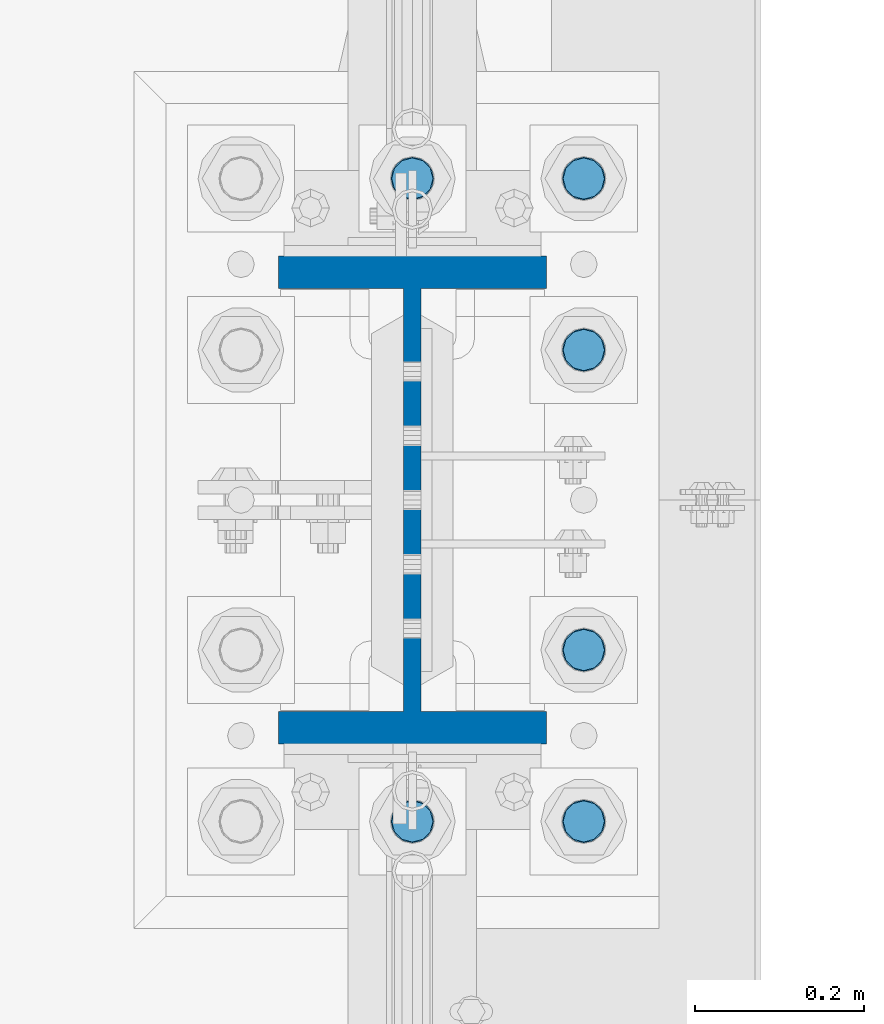
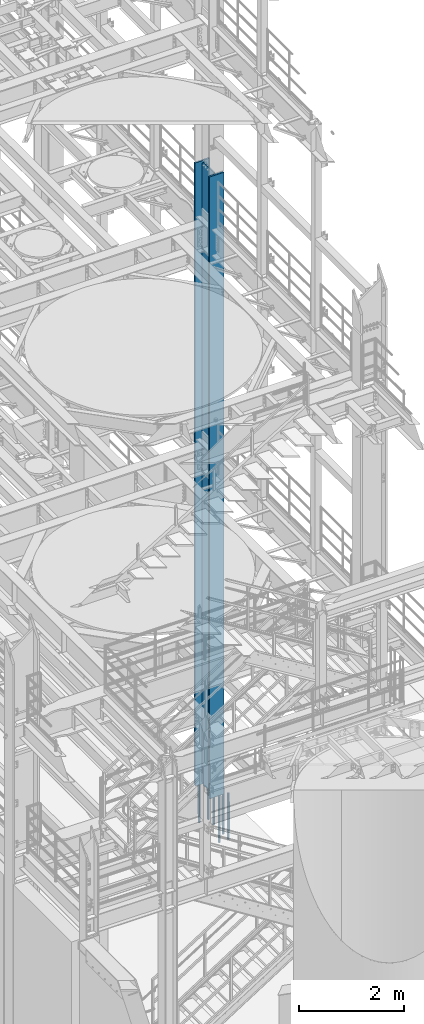
# One storey, part 715 of 1876: 7 columns, 2 elements without a shape of their own.
"""IFC2X3 building model written with IfcOpenShell, lengths in millimetres."""

from ifc_helpers import new_model, si_unit, frame, origin_with_axes, place, context, subcontext, project, spatial, faceted_brep, material, type_object, element, aggregate, save


model = new_model("IFC2X3")

# Units and contexts
model_context = context("Model", 3, precision=1e-05, world=origin_with_axes())
body_context = subcontext(model_context, "Body", "Model", "MODEL_VIEW")
ifc_project = project(units=[si_unit("LENGTHUNIT", "METRE", prefix="MILLI"), si_unit("AREAUNIT", "SQUARE_METRE"), si_unit("VOLUMEUNIT", "CUBIC_METRE"), si_unit("MASSUNIT", "GRAM", prefix="KILO"), si_unit("TIMEUNIT", "SECOND"), si_unit("PLANEANGLEUNIT", "RADIAN"), si_unit("SOLIDANGLEUNIT", "STERADIAN"), si_unit("THERMODYNAMICTEMPERATUREUNIT", "DEGREE_CELSIUS"), si_unit("LUMINOUSINTENSITYUNIT", "LUMEN")], contexts=[model_context])

# Site, building, storey
site_placement = place(None, origin_with_axes())
site = spatial("IfcSite", under=ifc_project, at=site_placement, CompositionType="ELEMENT")
building_placement = place(site_placement, origin_with_axes())
building = spatial("IfcBuilding", under=site, at=building_placement, Name="Undefined", CompositionType="ELEMENT")
storey_placement = place(building_placement, origin_with_axes())
storey = spatial("IfcBuildingStorey", under=building, at=storey_placement, Name="Undefined", CompositionType="ELEMENT", Elevation=0.0)

# Assembly, column
assembly_1_placement = place(storey_placement, origin_with_axes())
assembly_1 = element("IfcElementAssembly", 1, at=assembly_1_placement, inside=storey, Name="COLUMN", AssemblyPlace="NOTDEFINED", PredefinedType="RIGID_FRAME")
ifc_material_1 = material(Name="STEEL/A992")
column_type_1 = type_object("IfcColumnType", Name="W21X182", PredefinedType="NOTDEFINED")
column_1_placement = place(assembly_1_placement, frame((7620.0, 1524.0, 0.0), z_axis=(0.0, 1.0, 0.0), x_axis=(0.0, 0.0, 1.0)))
column_1 = element("IfcColumn", 2, at=column_1_placement, type_object=column_type_1, material=ifc_material_1, Name="COLUMN", ObjectType="W21X182", context=body_context, shape_type="Brep", body=[
    faceted_brep([(115.887500412823, 10.3187499999967, 200.025000762939), (115.887500412823, 10.3187500000004, -200.025000762939), (95.25, -10.3187500000004, -200.025000762939), (95.25, -10.3187500000004, 200.025000762939), (14528.8, -158.75, 288.925), (14528.8, 158.75, 288.925), (133.350000412822, 158.75, 288.925), (133.350000412824, -158.75, 288.925), (146.050000412824, -158.75, 250.825), (14478.0, -158.75, 250.825), (14528.8, -158.75, 250.825), (95.25, -158.75, 250.825), (146.050000412823, -10.3187500000004, 250.825), (14478.0, -10.3187500000004, 250.825), (14528.8, -10.3187500000004, 250.825), (95.25, -10.3187500000004, 250.825), (14528.8, -158.75, -288.925), (14528.8, -158.75, -250.825), (14478.0000007629, -158.75, -250.825), (146.050000412824, -158.75, -250.825), (95.25, -158.75, -250.825), (133.350000412824, -158.75, -288.925), (14528.8, 158.75, -288.925), (133.350000412822, 158.75, -288.925), (146.050000412824, 158.75, -250.825), (14478.0000007629, 158.75, -250.825), (14528.8, 158.75, -250.825), (95.25, 158.75, -250.825), (14528.8, 10.3187500000004, -250.825), (14528.8, -10.3187500000004, -250.825), (14478.0000007629, -10.3187500000004, -250.825), (146.050000412824, -10.3187500000004, -250.825), (95.25, -10.3187500000004, -250.825), (120.650000794293, -10.3187500000004, -200.025000762939), (120.650000794293, 10.3187500000004, -200.025000762939), (130.370159830384, 10.3187500000004, -201.958460608115), (130.370159830384, -10.3187500000004, -201.958460608115), (138.610512766692, 10.3187500000004, -207.464488409071), (138.610512766692, -10.3187500000004, -207.464488409071), (144.116540567648, 10.3187500000004, -215.704841345378), (144.116540567648, -10.3187500000004, -215.704841345378), (146.050000412823, 10.3187500000004, -225.42500038147), (146.050000412823, -10.3187500000004, -225.42500038147), (146.050000412824, 10.3187500000004, -250.825), (95.25, 10.3187500000004, -250.825), (14478.0000007629, 10.3187500000004, -250.825), (14481.8669204533, 10.3187500000004, -231.384681927818), (14481.8669204533, -10.3187500000004, -231.384681927818), (14492.8789760552, 10.3187500000004, -214.903976055203), (14492.8789760552, -10.3187500000004, -214.903976055203), (14509.3596819278, 10.3187500000004, -203.891920453291), (14509.3596819278, -10.3187500000004, -203.891920453291), (14528.8, -10.3187500000004, -200.025000762939), (14528.8, 10.3187500000004, -200.025000762939), (14528.8, 10.3187500000004, 200.025000762939), (14528.8, -10.3187500000004, 200.025000762939), (14509.3596811649, 10.3187500000004, 203.891920453291), (14509.3596811649, -10.3187500000004, 203.891920453291), (14492.8789752923, 10.3187500000004, 214.903976055203), (14492.8789752923, -10.3187500000004, 214.903976055203), (14481.8669196904, 10.3187500000004, 231.384681927818), (14481.8669196904, -10.3187500000004, 231.384681927818), (14478.0, 10.3187500000004, 250.825), (14528.8, 10.3187500000004, 250.825), (14528.8, 158.75, 250.825), (14478.0, 158.75, 250.825), (146.050000412824, 158.75, 250.825), (95.25, 158.75, 250.825), (95.25, 10.3187500000004, 250.825), (146.050000412824, 10.3187500000004, 250.825), (146.050000412823, 10.3187500000004, 225.42500038147), (146.050000412823, -10.3187500000004, 225.42500038147), (144.116540567648, 10.3187500000004, 215.704841345378), (144.116540567648, -10.3187500000004, 215.704841345378), (138.610512766692, 10.3187500000004, 207.464488409071), (138.610512766692, -10.3187500000004, 207.464488409071), (130.370159830384, 10.3187500000004, 201.958460608115), (130.370159830384, -10.3187500000004, 201.958460608115), (120.650000794293, 10.3187500000004, 200.025000762939), (120.650000794293, -10.3187500000004, 200.025000762939)], [[[0, 1, 2, 3]], [[4, 5, 6, 7]], [[8, 9, 10, 4, 7, 11]], [[12, 13, 14, 10, 9, 8, 11, 15]], [[16, 17, 18, 19, 20, 21]], [[22, 16, 21, 23]], [[24, 25, 26, 22, 23, 27]], [[17, 16, 22, 26, 28, 29]], [[19, 18, 17, 29, 30, 31, 32, 20]], [[33, 34, 35, 36]], [[36, 35, 37, 38]], [[38, 37, 39, 40]], [[40, 39, 41, 42]], [[42, 41, 43, 31]], [[31, 43, 44, 32]], [[27, 23, 21, 20, 32, 44]], [[43, 45, 28, 26, 25, 24, 27, 44]], [[29, 28, 45, 30]], [[30, 45, 46, 47]], [[47, 46, 48, 49]], [[49, 48, 50, 51]], [[52, 51, 50, 53]], [[54, 55, 52, 53]], [[55, 54, 56, 57]], [[57, 56, 58, 59]], [[59, 58, 60, 61]], [[61, 60, 62, 13]], [[14, 13, 62, 63]], [[64, 5, 4, 10, 14, 63]], [[5, 64, 65, 66, 67, 6]], [[11, 7, 6, 67, 68, 15]], [[66, 65, 64, 63, 62, 69, 68, 67]], [[15, 68, 69, 12]], [[12, 69, 70, 71]], [[71, 70, 72, 73]], [[73, 72, 74, 75]], [[75, 74, 76, 77]], [[77, 76, 78, 79]], [[79, 78, 0, 3]], [[33, 36, 38, 40, 42, 31, 30, 47, 49, 51, 52, 55, 57, 59, 61, 13, 12, 71, 73, 75, 77, 79, 3, 2]], [[34, 33, 2, 1]], [[78, 76, 74, 72, 70, 69, 62, 60, 58, 56, 54, 53, 50, 48, 46, 45, 43, 41, 39, 37, 35, 34, 1, 0]]]),
])
aggregate(assembly_1, [column_1])

# Assembly, columns
assembly_2_placement = place(storey_placement, origin_with_axes())
assembly_2 = element("IfcElementAssembly", 3, at=assembly_2_placement, inside=storey, Name="TEMPLATE", AssemblyPlace="NOTDEFINED", PredefinedType="RIGID_FRAME")
ifc_material_2 = material(Name="STEEL/F1554-GR.105")
column_type_2 = type_object("IfcColumnType", PredefinedType="NOTDEFINED")
column_2_placement = place(assembly_2_placement, frame((7620.0, 1143.0, 0.0), z_axis=(0.0, -1.0, 0.0), x_axis=(0.0, 0.0, -1.0)))
column_2 = element("IfcColumn", 4, at=column_2_placement, type_object=column_type_2, material=ifc_material_2, Name="ANCHOR_BOLTS", context=body_context, shape_type="Brep", body=[
    faceted_brep([(-196.85, -21.217622392719, 12.25), (-196.85, -12.25, 21.2176223927188), (-196.85, 0.0, 24.5), (-196.85, 12.25, 21.2176223927188), (-196.85, 21.217622392719, 12.25), (-196.85, 24.5, 0.0), (-196.85, 21.217622392719, -12.25), (-196.85, 12.25, -21.2176223927188), (-196.85, 0.0, -24.5), (-196.85, -12.25, -21.2176223927188), (-196.85, -21.217622392719, -12.25), (-196.85, -24.5, 0.0), (0.0, 24.5, 0.0), (0.0, 21.217622392719, -12.25), (0.0, 12.25, -21.2176223927188), (0.0, 0.0, -24.5), (0.0, -12.25, -21.2176223927188), (0.0, -21.217622392719, -12.25), (0.0, -24.5, 0.0), (0.0, -21.217622392719, 12.25), (0.0, -12.25, 21.2176223927188), (0.0, 0.0, 24.5), (0.0, 12.25, 21.2176223927188), (0.0, 21.217622392719, 12.25), (0.0, -23.4665401257871, 9.7201591820733), (0.0, -17.9605122421381, 17.9605122421383), (0.0, -9.72015918207308, 23.4665401257867), (0.0, 0.0, 25.4000000000001), (0.0, 9.72015918207308, 23.4665401257867), (0.0, 17.9605122421381, 17.9605122421383), (0.0, 23.4665401257871, 9.7201591820733), (0.0, 25.3999996185339, 9.09494701772928e-13), (0.0, 23.4665401257871, -9.7201591820733), (0.0, 17.9605122421381, -17.9605122421383), (0.0, 9.72015918207308, -23.4665401257867), (0.0, 0.0, -25.4000000000001), (0.0, -9.72015918207308, -23.4665401257867), (0.0, -17.9605122421381, -17.9605122421383), (0.0, -23.4665401257871, -9.7201591820733), (0.0, -25.3999996185375, 0.0), (673.1, -25.3999999999996, 0.0), (673.1, -23.4665401257871, 9.7201591820733), (673.1, -17.9605122421381, 17.9605122421383), (673.1, -9.72015918207308, 23.4665401257867), (673.1, 0.0, 25.4000000000001), (673.1, 9.72015918207308, 23.4665401257867), (673.1, 17.9605122421381, 17.9605122421383), (673.1, 23.4665401257871, 9.7201591820733), (673.1, 25.3999999999996, 0.0), (673.1, 23.4665401257871, -9.7201591820733), (673.1, 17.9605122421381, -17.9605122421383), (673.1, 9.72015918207308, -23.4665401257867), (673.1, 0.0, -25.4000000000001), (673.1, -9.72015918207308, -23.4665401257867), (673.1, -17.9605122421381, -17.9605122421383), (673.1, -23.4665401257871, -9.7201591820733), (673.1, -12.25, 21.2176223927188), (673.1, 0.0, 24.5), (673.1, 12.25, 21.2176223927188), (673.1, 21.217622392719, 12.25), (673.1, 24.5, 0.0), (673.1, 21.217622392719, -12.25), (673.1, 12.25, -21.2176223927188), (673.1, 0.0, -24.5), (673.1, -12.25, -21.2176223927188), (673.1, -21.217622392719, -12.25), (673.1, -24.5, 0.0), (673.1, -21.217622392719, 12.25), (869.95, -12.25, -21.2176223927188), (869.95, 0.0, -24.5), (869.95, 12.25, -21.2176223927188), (869.95, 21.217622392719, -12.25), (869.95, 24.5, 0.0), (869.95, 21.217622392719, 12.25), (869.95, 12.25, 21.2176223927188), (869.95, 0.0, 24.5), (869.95, -12.25, 21.2176223927188), (869.95, -21.217622392719, 12.25), (869.95, -24.5, 0.0), (869.95, -21.217622392719, -12.25)], [[[0, 1, 2, 3, 4, 5, 6, 7, 8, 9, 10, 11]], [[6, 5, 12, 13]], [[7, 6, 13, 14]], [[8, 7, 14, 15]], [[9, 8, 15, 16]], [[10, 9, 16, 17]], [[11, 10, 17, 18]], [[0, 11, 18, 19]], [[1, 0, 19, 20]], [[2, 1, 20, 21]], [[3, 2, 21, 22]], [[4, 3, 22, 23]], [[5, 4, 23, 12]], [[24, 25, 26, 27, 28, 29, 30, 31, 32, 33, 34, 35, 36, 37, 38, 39], [22, 21, 20, 19, 18, 17, 16, 15, 14, 13, 12, 23]], [[24, 39, 40, 41]], [[25, 24, 41, 42]], [[26, 25, 42, 43]], [[27, 26, 43, 44]], [[28, 27, 44, 45]], [[29, 28, 45, 46]], [[30, 29, 46, 47]], [[31, 30, 47, 48]], [[32, 31, 48, 49]], [[33, 32, 49, 50]], [[34, 33, 50, 51]], [[35, 34, 51, 52]], [[36, 35, 52, 53]], [[37, 36, 53, 54]], [[38, 37, 54, 55]], [[39, 38, 55, 40]], [[54, 53, 52, 51, 50, 49, 48, 47, 46, 45, 44, 43, 42, 41, 40, 55], [56, 57, 58, 59, 60, 61, 62, 63, 64, 65, 66, 67]], [[68, 69, 70, 71, 72, 73, 74, 75, 76, 77, 78, 79]], [[76, 75, 57, 56]], [[77, 76, 56, 67]], [[78, 77, 67, 66]], [[79, 78, 66, 65]], [[68, 79, 65, 64]], [[69, 68, 64, 63]], [[70, 69, 63, 62]], [[71, 70, 62, 61]], [[72, 71, 61, 60]], [[73, 72, 60, 59]], [[74, 73, 59, 58]], [[75, 74, 58, 57]]]),
])
column_3_placement = place(assembly_2_placement, frame((7823.2, 1143.0, 0.0), z_axis=(0.0, 1.0, 0.0), x_axis=(0.0, 0.0, -1.0)))
column_3 = element("IfcColumn", 5, at=column_3_placement, type_object=column_type_2, material=ifc_material_2, Name="ANCHOR_BOLTS", context=body_context, shape_type="Brep", body=[
    faceted_brep([(-196.85, -21.217622392719, 12.25), (-196.85, -12.25, 21.2176223927188), (-196.85, 0.0, 24.5), (-196.85, 12.25, 21.2176223927188), (-196.85, 21.217622392719, 12.25), (-196.85, 24.5, 0.0), (-196.85, 21.217622392719, -12.25), (-196.85, 12.25, -21.2176223927188), (-196.85, 0.0, -24.5), (-196.85, -12.25, -21.2176223927188), (-196.85, -21.217622392719, -12.25), (-196.85, -24.5, 0.0), (0.0, 24.5, 0.0), (0.0, 21.217622392719, -12.25), (0.0, 12.25, -21.2176223927188), (0.0, 0.0, -24.5), (0.0, -12.25, -21.2176223927188), (0.0, -21.217622392719, -12.25), (0.0, -24.5, 0.0), (0.0, -21.217622392719, 12.25), (0.0, -12.25, 21.2176223927188), (0.0, 0.0, 24.5), (0.0, 12.25, 21.2176223927188), (0.0, 21.217622392719, 12.25), (0.0, -23.4665401257871, 9.7201591820733), (0.0, -17.9605122421381, 17.9605122421383), (0.0, -9.72015918207308, 23.4665401257867), (0.0, 0.0, 25.4000000000001), (0.0, 9.72015918207308, 23.4665401257867), (0.0, 17.9605122421381, 17.9605122421383), (0.0, 23.4665401257871, 9.7201591820733), (0.0, 25.3999996185339, 9.09494701772928e-13), (0.0, 23.4665401257871, -9.7201591820733), (0.0, 17.9605122421381, -17.9605122421383), (0.0, 9.72015918207308, -23.4665401257867), (0.0, 0.0, -25.4000000000001), (0.0, -9.72015918207308, -23.4665401257867), (0.0, -17.9605122421381, -17.9605122421383), (0.0, -23.4665401257871, -9.7201591820733), (0.0, -25.3999996185375, 0.0), (673.1, -25.3999999999996, 0.0), (673.1, -23.4665401257871, 9.7201591820733), (673.1, -17.9605122421381, 17.9605122421383), (673.1, -9.72015918207308, 23.4665401257867), (673.1, 0.0, 25.4000000000001), (673.1, 9.72015918207308, 23.4665401257867), (673.1, 17.9605122421381, 17.9605122421383), (673.1, 23.4665401257871, 9.7201591820733), (673.1, 25.3999999999996, 0.0), (673.1, 23.4665401257871, -9.7201591820733), (673.1, 17.9605122421381, -17.9605122421383), (673.1, 9.72015918207308, -23.4665401257867), (673.1, 0.0, -25.4000000000001), (673.1, -9.72015918207308, -23.4665401257867), (673.1, -17.9605122421381, -17.9605122421383), (673.1, -23.4665401257871, -9.7201591820733), (673.1, -12.25, 21.2176223927188), (673.1, 0.0, 24.5), (673.1, 12.25, 21.2176223927188), (673.1, 21.217622392719, 12.25), (673.1, 24.5, 0.0), (673.1, 21.217622392719, -12.25), (673.1, 12.25, -21.2176223927188), (673.1, 0.0, -24.5), (673.1, -12.25, -21.2176223927188), (673.1, -21.217622392719, -12.25), (673.1, -24.5, 0.0), (673.1, -21.217622392719, 12.25), (869.95, -12.25, -21.2176223927188), (869.95, 0.0, -24.5), (869.95, 12.25, -21.2176223927188), (869.95, 21.217622392719, -12.25), (869.95, 24.5, 0.0), (869.95, 21.217622392719, 12.25), (869.95, 12.25, 21.2176223927188), (869.95, 0.0, 24.5), (869.95, -12.25, 21.2176223927188), (869.95, -21.217622392719, 12.25), (869.95, -24.5, 0.0), (869.95, -21.217622392719, -12.25)], [[[0, 1, 2, 3, 4, 5, 6, 7, 8, 9, 10, 11]], [[6, 5, 12, 13]], [[7, 6, 13, 14]], [[8, 7, 14, 15]], [[9, 8, 15, 16]], [[10, 9, 16, 17]], [[11, 10, 17, 18]], [[0, 11, 18, 19]], [[1, 0, 19, 20]], [[2, 1, 20, 21]], [[3, 2, 21, 22]], [[4, 3, 22, 23]], [[5, 4, 23, 12]], [[24, 25, 26, 27, 28, 29, 30, 31, 32, 33, 34, 35, 36, 37, 38, 39], [22, 21, 20, 19, 18, 17, 16, 15, 14, 13, 12, 23]], [[24, 39, 40, 41]], [[25, 24, 41, 42]], [[26, 25, 42, 43]], [[27, 26, 43, 44]], [[28, 27, 44, 45]], [[29, 28, 45, 46]], [[30, 29, 46, 47]], [[31, 30, 47, 48]], [[32, 31, 48, 49]], [[33, 32, 49, 50]], [[34, 33, 50, 51]], [[35, 34, 51, 52]], [[36, 35, 52, 53]], [[37, 36, 53, 54]], [[38, 37, 54, 55]], [[39, 38, 55, 40]], [[54, 53, 52, 51, 50, 49, 48, 47, 46, 45, 44, 43, 42, 41, 40, 55], [56, 57, 58, 59, 60, 61, 62, 63, 64, 65, 66, 67]], [[68, 69, 70, 71, 72, 73, 74, 75, 76, 77, 78, 79]], [[76, 75, 57, 56]], [[77, 76, 56, 67]], [[78, 77, 67, 66]], [[79, 78, 66, 65]], [[68, 79, 65, 64]], [[69, 68, 64, 63]], [[70, 69, 63, 62]], [[71, 70, 62, 61]], [[72, 71, 61, 60]], [[73, 72, 60, 59]], [[74, 73, 59, 58]], [[75, 74, 58, 57]]]),
])
column_4_placement = place(assembly_2_placement, frame((7823.2, 1346.2, 0.0), z_axis=(0.0, 1.0, 0.0), x_axis=(0.0, 0.0, -1.0)))
column_4 = element("IfcColumn", 6, at=column_4_placement, type_object=column_type_2, material=ifc_material_2, Name="ANCHOR_BOLTS", context=body_context, shape_type="Brep", body=[
    faceted_brep([(-196.85, -21.217622392719, 12.25), (-196.85, -12.25, 21.2176223927188), (-196.85, 0.0, 24.5), (-196.85, 12.25, 21.2176223927188), (-196.85, 21.217622392719, 12.25), (-196.85, 24.5, 0.0), (-196.85, 21.217622392719, -12.25), (-196.85, 12.25, -21.2176223927188), (-196.85, 0.0, -24.5), (-196.85, -12.25, -21.2176223927188), (-196.85, -21.217622392719, -12.25), (-196.85, -24.5, 0.0), (0.0, 24.5, 0.0), (0.0, 21.217622392719, -12.25), (0.0, 12.25, -21.2176223927188), (0.0, 0.0, -24.5), (0.0, -12.25, -21.2176223927188), (0.0, -21.217622392719, -12.25), (0.0, -24.5, 0.0), (0.0, -21.217622392719, 12.25), (0.0, -12.25, 21.2176223927188), (0.0, 0.0, 24.5), (0.0, 12.25, 21.2176223927188), (0.0, 21.217622392719, 12.25), (0.0, -23.4665401257871, 9.7201591820733), (0.0, -17.9605122421381, 17.9605122421383), (0.0, -9.72015918207308, 23.4665401257867), (0.0, 0.0, 25.4000000000001), (0.0, 9.72015918207308, 23.4665401257867), (0.0, 17.9605122421381, 17.9605122421383), (0.0, 23.4665401257871, 9.7201591820733), (0.0, 25.3999996185339, 9.09494701772928e-13), (0.0, 23.4665401257871, -9.7201591820733), (0.0, 17.9605122421381, -17.9605122421383), (0.0, 9.72015918207308, -23.4665401257867), (0.0, 0.0, -25.4000000000001), (0.0, -9.72015918207308, -23.4665401257867), (0.0, -17.9605122421381, -17.9605122421383), (0.0, -23.4665401257871, -9.7201591820733), (0.0, -25.3999996185375, 0.0), (673.1, -25.3999999999996, 0.0), (673.1, -23.4665401257871, 9.7201591820733), (673.1, -17.9605122421381, 17.9605122421383), (673.1, -9.72015918207308, 23.4665401257867), (673.1, 0.0, 25.4000000000001), (673.1, 9.72015918207308, 23.4665401257867), (673.1, 17.9605122421381, 17.9605122421383), (673.1, 23.4665401257871, 9.7201591820733), (673.1, 25.3999999999996, 0.0), (673.1, 23.4665401257871, -9.7201591820733), (673.1, 17.9605122421381, -17.9605122421383), (673.1, 9.72015918207308, -23.4665401257867), (673.1, 0.0, -25.4000000000001), (673.1, -9.72015918207308, -23.4665401257867), (673.1, -17.9605122421381, -17.9605122421383), (673.1, -23.4665401257871, -9.7201591820733), (673.1, -12.25, 21.2176223927188), (673.1, 0.0, 24.5), (673.1, 12.25, 21.2176223927188), (673.1, 21.217622392719, 12.25), (673.1, 24.5, 0.0), (673.1, 21.217622392719, -12.25), (673.1, 12.25, -21.2176223927188), (673.1, 0.0, -24.5), (673.1, -12.25, -21.2176223927188), (673.1, -21.217622392719, -12.25), (673.1, -24.5, 0.0), (673.1, -21.217622392719, 12.25), (869.95, -12.25, -21.2176223927188), (869.95, 0.0, -24.5), (869.95, 12.25, -21.2176223927188), (869.95, 21.217622392719, -12.25), (869.95, 24.5, 0.0), (869.95, 21.217622392719, 12.25), (869.95, 12.25, 21.2176223927188), (869.95, 0.0, 24.5), (869.95, -12.25, 21.2176223927188), (869.95, -21.217622392719, 12.25), (869.95, -24.5, 0.0), (869.95, -21.217622392719, -12.25)], [[[0, 1, 2, 3, 4, 5, 6, 7, 8, 9, 10, 11]], [[6, 5, 12, 13]], [[7, 6, 13, 14]], [[8, 7, 14, 15]], [[9, 8, 15, 16]], [[10, 9, 16, 17]], [[11, 10, 17, 18]], [[0, 11, 18, 19]], [[1, 0, 19, 20]], [[2, 1, 20, 21]], [[3, 2, 21, 22]], [[4, 3, 22, 23]], [[5, 4, 23, 12]], [[24, 25, 26, 27, 28, 29, 30, 31, 32, 33, 34, 35, 36, 37, 38, 39], [22, 21, 20, 19, 18, 17, 16, 15, 14, 13, 12, 23]], [[24, 39, 40, 41]], [[25, 24, 41, 42]], [[26, 25, 42, 43]], [[27, 26, 43, 44]], [[28, 27, 44, 45]], [[29, 28, 45, 46]], [[30, 29, 46, 47]], [[31, 30, 47, 48]], [[32, 31, 48, 49]], [[33, 32, 49, 50]], [[34, 33, 50, 51]], [[35, 34, 51, 52]], [[36, 35, 52, 53]], [[37, 36, 53, 54]], [[38, 37, 54, 55]], [[39, 38, 55, 40]], [[54, 53, 52, 51, 50, 49, 48, 47, 46, 45, 44, 43, 42, 41, 40, 55], [56, 57, 58, 59, 60, 61, 62, 63, 64, 65, 66, 67]], [[68, 69, 70, 71, 72, 73, 74, 75, 76, 77, 78, 79]], [[76, 75, 57, 56]], [[77, 76, 56, 67]], [[78, 77, 67, 66]], [[79, 78, 66, 65]], [[68, 79, 65, 64]], [[69, 68, 64, 63]], [[70, 69, 63, 62]], [[71, 70, 62, 61]], [[72, 71, 61, 60]], [[73, 72, 60, 59]], [[74, 73, 59, 58]], [[75, 74, 58, 57]]]),
])
column_5_placement = place(assembly_2_placement, frame((7823.2, 1701.8, 0.0), z_axis=(0.0, 1.0, 0.0), x_axis=(0.0, 0.0, -1.0)))
column_5 = element("IfcColumn", 7, at=column_5_placement, type_object=column_type_2, material=ifc_material_2, Name="ANCHOR_BOLTS", context=body_context, shape_type="Brep", body=[
    faceted_brep([(-196.85, -21.217622392719, 12.25), (-196.85, -12.25, 21.2176223927188), (-196.85, 0.0, 24.5), (-196.85, 12.25, 21.2176223927188), (-196.85, 21.217622392719, 12.25), (-196.85, 24.5, 0.0), (-196.85, 21.217622392719, -12.25), (-196.85, 12.25, -21.2176223927188), (-196.85, 0.0, -24.5), (-196.85, -12.25, -21.2176223927188), (-196.85, -21.217622392719, -12.25), (-196.85, -24.5, 0.0), (0.0, 24.5, 0.0), (0.0, 21.217622392719, -12.25), (0.0, 12.25, -21.2176223927188), (0.0, 0.0, -24.5), (0.0, -12.25, -21.2176223927188), (0.0, -21.217622392719, -12.25), (0.0, -24.5, 0.0), (0.0, -21.217622392719, 12.25), (0.0, -12.25, 21.2176223927188), (0.0, 0.0, 24.5), (0.0, 12.25, 21.2176223927188), (0.0, 21.217622392719, 12.25), (0.0, -23.4665401257871, 9.7201591820733), (0.0, -17.9605122421381, 17.9605122421383), (0.0, -9.72015918207308, 23.4665401257867), (0.0, 0.0, 25.4000000000001), (0.0, 9.72015918207308, 23.4665401257867), (0.0, 17.9605122421381, 17.9605122421383), (0.0, 23.4665401257871, 9.7201591820733), (0.0, 25.3999996185339, 9.09494701772928e-13), (0.0, 23.4665401257871, -9.7201591820733), (0.0, 17.9605122421381, -17.9605122421383), (0.0, 9.72015918207308, -23.4665401257867), (0.0, 0.0, -25.4000000000001), (0.0, -9.72015918207308, -23.4665401257867), (0.0, -17.9605122421381, -17.9605122421383), (0.0, -23.4665401257871, -9.7201591820733), (0.0, -25.3999996185375, 0.0), (673.1, -25.3999999999996, 0.0), (673.1, -23.4665401257871, 9.7201591820733), (673.1, -17.9605122421381, 17.9605122421383), (673.1, -9.72015918207308, 23.4665401257867), (673.1, 0.0, 25.4000000000001), (673.1, 9.72015918207308, 23.4665401257867), (673.1, 17.9605122421381, 17.9605122421383), (673.1, 23.4665401257871, 9.7201591820733), (673.1, 25.3999999999996, 0.0), (673.1, 23.4665401257871, -9.7201591820733), (673.1, 17.9605122421381, -17.9605122421383), (673.1, 9.72015918207308, -23.4665401257867), (673.1, 0.0, -25.4000000000001), (673.1, -9.72015918207308, -23.4665401257867), (673.1, -17.9605122421381, -17.9605122421383), (673.1, -23.4665401257871, -9.7201591820733), (673.1, -12.25, 21.2176223927188), (673.1, 0.0, 24.5), (673.1, 12.25, 21.2176223927188), (673.1, 21.217622392719, 12.25), (673.1, 24.5, 0.0), (673.1, 21.217622392719, -12.25), (673.1, 12.25, -21.2176223927188), (673.1, 0.0, -24.5), (673.1, -12.25, -21.2176223927188), (673.1, -21.217622392719, -12.25), (673.1, -24.5, 0.0), (673.1, -21.217622392719, 12.25), (869.95, -12.25, -21.2176223927188), (869.95, 0.0, -24.5), (869.95, 12.25, -21.2176223927188), (869.95, 21.217622392719, -12.25), (869.95, 24.5, 0.0), (869.95, 21.217622392719, 12.25), (869.95, 12.25, 21.2176223927188), (869.95, 0.0, 24.5), (869.95, -12.25, 21.2176223927188), (869.95, -21.217622392719, 12.25), (869.95, -24.5, 0.0), (869.95, -21.217622392719, -12.25)], [[[0, 1, 2, 3, 4, 5, 6, 7, 8, 9, 10, 11]], [[6, 5, 12, 13]], [[7, 6, 13, 14]], [[8, 7, 14, 15]], [[9, 8, 15, 16]], [[10, 9, 16, 17]], [[11, 10, 17, 18]], [[0, 11, 18, 19]], [[1, 0, 19, 20]], [[2, 1, 20, 21]], [[3, 2, 21, 22]], [[4, 3, 22, 23]], [[5, 4, 23, 12]], [[24, 25, 26, 27, 28, 29, 30, 31, 32, 33, 34, 35, 36, 37, 38, 39], [22, 21, 20, 19, 18, 17, 16, 15, 14, 13, 12, 23]], [[24, 39, 40, 41]], [[25, 24, 41, 42]], [[26, 25, 42, 43]], [[27, 26, 43, 44]], [[28, 27, 44, 45]], [[29, 28, 45, 46]], [[30, 29, 46, 47]], [[31, 30, 47, 48]], [[32, 31, 48, 49]], [[33, 32, 49, 50]], [[34, 33, 50, 51]], [[35, 34, 51, 52]], [[36, 35, 52, 53]], [[37, 36, 53, 54]], [[38, 37, 54, 55]], [[39, 38, 55, 40]], [[54, 53, 52, 51, 50, 49, 48, 47, 46, 45, 44, 43, 42, 41, 40, 55], [56, 57, 58, 59, 60, 61, 62, 63, 64, 65, 66, 67]], [[68, 69, 70, 71, 72, 73, 74, 75, 76, 77, 78, 79]], [[76, 75, 57, 56]], [[77, 76, 56, 67]], [[78, 77, 67, 66]], [[79, 78, 66, 65]], [[68, 79, 65, 64]], [[69, 68, 64, 63]], [[70, 69, 63, 62]], [[71, 70, 62, 61]], [[72, 71, 61, 60]], [[73, 72, 60, 59]], [[74, 73, 59, 58]], [[75, 74, 58, 57]]]),
])
column_6_placement = place(assembly_2_placement, frame((7620.0, 1905.0, 0.0), z_axis=(0.0, -1.0, 0.0), x_axis=(0.0, 0.0, -1.0)))
column_6 = element("IfcColumn", 8, at=column_6_placement, type_object=column_type_2, material=ifc_material_2, Name="ANCHOR_BOLTS", context=body_context, shape_type="Brep", body=[
    faceted_brep([(-196.85, -21.217622392719, 12.25), (-196.85, -12.25, 21.2176223927188), (-196.85, 0.0, 24.5), (-196.85, 12.25, 21.2176223927188), (-196.85, 21.217622392719, 12.25), (-196.85, 24.5, 0.0), (-196.85, 21.217622392719, -12.25), (-196.85, 12.25, -21.2176223927188), (-196.85, 0.0, -24.5), (-196.85, -12.25, -21.2176223927188), (-196.85, -21.217622392719, -12.25), (-196.85, -24.5, 0.0), (0.0, 24.5, 0.0), (0.0, 21.217622392719, -12.25), (0.0, 12.25, -21.2176223927188), (0.0, 0.0, -24.5), (0.0, -12.25, -21.2176223927188), (0.0, -21.217622392719, -12.25), (0.0, -24.5, 0.0), (0.0, -21.217622392719, 12.25), (0.0, -12.25, 21.2176223927188), (0.0, 0.0, 24.5), (0.0, 12.25, 21.2176223927188), (0.0, 21.217622392719, 12.25), (0.0, -23.4665401257871, 9.7201591820733), (0.0, -17.9605122421381, 17.9605122421383), (0.0, -9.72015918207308, 23.4665401257867), (0.0, 0.0, 25.4000000000001), (0.0, 9.72015918207308, 23.4665401257867), (0.0, 17.9605122421381, 17.9605122421383), (0.0, 23.4665401257871, 9.7201591820733), (0.0, 25.3999996185339, 9.09494701772928e-13), (0.0, 23.4665401257871, -9.7201591820733), (0.0, 17.9605122421381, -17.9605122421383), (0.0, 9.72015918207308, -23.4665401257867), (0.0, 0.0, -25.4000000000001), (0.0, -9.72015918207308, -23.4665401257867), (0.0, -17.9605122421381, -17.9605122421383), (0.0, -23.4665401257871, -9.7201591820733), (0.0, -25.3999996185375, 0.0), (673.1, -25.3999999999996, 0.0), (673.1, -23.4665401257871, 9.7201591820733), (673.1, -17.9605122421381, 17.9605122421383), (673.1, -9.72015918207308, 23.4665401257867), (673.1, 0.0, 25.4000000000001), (673.1, 9.72015918207308, 23.4665401257867), (673.1, 17.9605122421381, 17.9605122421383), (673.1, 23.4665401257871, 9.7201591820733), (673.1, 25.3999999999996, 0.0), (673.1, 23.4665401257871, -9.7201591820733), (673.1, 17.9605122421381, -17.9605122421383), (673.1, 9.72015918207308, -23.4665401257867), (673.1, 0.0, -25.4000000000001), (673.1, -9.72015918207308, -23.4665401257867), (673.1, -17.9605122421381, -17.9605122421383), (673.1, -23.4665401257871, -9.7201591820733), (673.1, -12.25, 21.2176223927188), (673.1, 0.0, 24.5), (673.1, 12.25, 21.2176223927188), (673.1, 21.217622392719, 12.25), (673.1, 24.5, 0.0), (673.1, 21.217622392719, -12.25), (673.1, 12.25, -21.2176223927188), (673.1, 0.0, -24.5), (673.1, -12.25, -21.2176223927188), (673.1, -21.217622392719, -12.25), (673.1, -24.5, 0.0), (673.1, -21.217622392719, 12.25), (869.95, -12.25, -21.2176223927188), (869.95, 0.0, -24.5), (869.95, 12.25, -21.2176223927188), (869.95, 21.217622392719, -12.25), (869.95, 24.5, 0.0), (869.95, 21.217622392719, 12.25), (869.95, 12.25, 21.2176223927188), (869.95, 0.0, 24.5), (869.95, -12.25, 21.2176223927188), (869.95, -21.217622392719, 12.25), (869.95, -24.5, 0.0), (869.95, -21.217622392719, -12.25)], [[[0, 1, 2, 3, 4, 5, 6, 7, 8, 9, 10, 11]], [[6, 5, 12, 13]], [[7, 6, 13, 14]], [[8, 7, 14, 15]], [[9, 8, 15, 16]], [[10, 9, 16, 17]], [[11, 10, 17, 18]], [[0, 11, 18, 19]], [[1, 0, 19, 20]], [[2, 1, 20, 21]], [[3, 2, 21, 22]], [[4, 3, 22, 23]], [[5, 4, 23, 12]], [[24, 25, 26, 27, 28, 29, 30, 31, 32, 33, 34, 35, 36, 37, 38, 39], [22, 21, 20, 19, 18, 17, 16, 15, 14, 13, 12, 23]], [[24, 39, 40, 41]], [[25, 24, 41, 42]], [[26, 25, 42, 43]], [[27, 26, 43, 44]], [[28, 27, 44, 45]], [[29, 28, 45, 46]], [[30, 29, 46, 47]], [[31, 30, 47, 48]], [[32, 31, 48, 49]], [[33, 32, 49, 50]], [[34, 33, 50, 51]], [[35, 34, 51, 52]], [[36, 35, 52, 53]], [[37, 36, 53, 54]], [[38, 37, 54, 55]], [[39, 38, 55, 40]], [[54, 53, 52, 51, 50, 49, 48, 47, 46, 45, 44, 43, 42, 41, 40, 55], [56, 57, 58, 59, 60, 61, 62, 63, 64, 65, 66, 67]], [[68, 69, 70, 71, 72, 73, 74, 75, 76, 77, 78, 79]], [[76, 75, 57, 56]], [[77, 76, 56, 67]], [[78, 77, 67, 66]], [[79, 78, 66, 65]], [[68, 79, 65, 64]], [[69, 68, 64, 63]], [[70, 69, 63, 62]], [[71, 70, 62, 61]], [[72, 71, 61, 60]], [[73, 72, 60, 59]], [[74, 73, 59, 58]], [[75, 74, 58, 57]]]),
])
column_7_placement = place(assembly_2_placement, frame((7823.2, 1905.0, 0.0), z_axis=(0.0, 1.0, 0.0), x_axis=(0.0, 0.0, -1.0)))
column_7 = element("IfcColumn", 9, at=column_7_placement, type_object=column_type_2, material=ifc_material_2, Name="ANCHOR_BOLTS", context=body_context, shape_type="Brep", body=[
    faceted_brep([(-196.85, -21.217622392719, 12.25), (-196.85, -12.25, 21.2176223927188), (-196.85, 0.0, 24.5), (-196.85, 12.25, 21.2176223927188), (-196.85, 21.217622392719, 12.25), (-196.85, 24.5, 0.0), (-196.85, 21.217622392719, -12.25), (-196.85, 12.25, -21.2176223927188), (-196.85, 0.0, -24.5), (-196.85, -12.25, -21.2176223927188), (-196.85, -21.217622392719, -12.25), (-196.85, -24.5, 0.0), (0.0, 24.5, 0.0), (0.0, 21.217622392719, -12.25), (0.0, 12.25, -21.2176223927188), (0.0, 0.0, -24.5), (0.0, -12.25, -21.2176223927188), (0.0, -21.217622392719, -12.25), (0.0, -24.5, 0.0), (0.0, -21.217622392719, 12.25), (0.0, -12.25, 21.2176223927188), (0.0, 0.0, 24.5), (0.0, 12.25, 21.2176223927188), (0.0, 21.217622392719, 12.25), (0.0, -23.4665401257871, 9.7201591820733), (0.0, -17.9605122421381, 17.9605122421383), (0.0, -9.72015918207308, 23.4665401257867), (0.0, 0.0, 25.4000000000001), (0.0, 9.72015918207308, 23.4665401257867), (0.0, 17.9605122421381, 17.9605122421383), (0.0, 23.4665401257871, 9.7201591820733), (0.0, 25.3999996185339, 9.09494701772928e-13), (0.0, 23.4665401257871, -9.7201591820733), (0.0, 17.9605122421381, -17.9605122421383), (0.0, 9.72015918207308, -23.4665401257867), (0.0, 0.0, -25.4000000000001), (0.0, -9.72015918207308, -23.4665401257867), (0.0, -17.9605122421381, -17.9605122421383), (0.0, -23.4665401257871, -9.7201591820733), (0.0, -25.3999996185375, 0.0), (673.1, -25.3999999999996, 0.0), (673.1, -23.4665401257871, 9.7201591820733), (673.1, -17.9605122421381, 17.9605122421383), (673.1, -9.72015918207308, 23.4665401257867), (673.1, 0.0, 25.4000000000001), (673.1, 9.72015918207308, 23.4665401257867), (673.1, 17.9605122421381, 17.9605122421383), (673.1, 23.4665401257871, 9.7201591820733), (673.1, 25.3999999999996, 0.0), (673.1, 23.4665401257871, -9.7201591820733), (673.1, 17.9605122421381, -17.9605122421383), (673.1, 9.72015918207308, -23.4665401257867), (673.1, 0.0, -25.4000000000001), (673.1, -9.72015918207308, -23.4665401257867), (673.1, -17.9605122421381, -17.9605122421383), (673.1, -23.4665401257871, -9.7201591820733), (673.1, -12.25, 21.2176223927188), (673.1, 0.0, 24.5), (673.1, 12.25, 21.2176223927188), (673.1, 21.217622392719, 12.25), (673.1, 24.5, 0.0), (673.1, 21.217622392719, -12.25), (673.1, 12.25, -21.2176223927188), (673.1, 0.0, -24.5), (673.1, -12.25, -21.2176223927188), (673.1, -21.217622392719, -12.25), (673.1, -24.5, 0.0), (673.1, -21.217622392719, 12.25), (869.95, -12.25, -21.2176223927188), (869.95, 0.0, -24.5), (869.95, 12.25, -21.2176223927188), (869.95, 21.217622392719, -12.25), (869.95, 24.5, 0.0), (869.95, 21.217622392719, 12.25), (869.95, 12.25, 21.2176223927188), (869.95, 0.0, 24.5), (869.95, -12.25, 21.2176223927188), (869.95, -21.217622392719, 12.25), (869.95, -24.5, 0.0), (869.95, -21.217622392719, -12.25)], [[[0, 1, 2, 3, 4, 5, 6, 7, 8, 9, 10, 11]], [[6, 5, 12, 13]], [[7, 6, 13, 14]], [[8, 7, 14, 15]], [[9, 8, 15, 16]], [[10, 9, 16, 17]], [[11, 10, 17, 18]], [[0, 11, 18, 19]], [[1, 0, 19, 20]], [[2, 1, 20, 21]], [[3, 2, 21, 22]], [[4, 3, 22, 23]], [[5, 4, 23, 12]], [[24, 25, 26, 27, 28, 29, 30, 31, 32, 33, 34, 35, 36, 37, 38, 39], [22, 21, 20, 19, 18, 17, 16, 15, 14, 13, 12, 23]], [[24, 39, 40, 41]], [[25, 24, 41, 42]], [[26, 25, 42, 43]], [[27, 26, 43, 44]], [[28, 27, 44, 45]], [[29, 28, 45, 46]], [[30, 29, 46, 47]], [[31, 30, 47, 48]], [[32, 31, 48, 49]], [[33, 32, 49, 50]], [[34, 33, 50, 51]], [[35, 34, 51, 52]], [[36, 35, 52, 53]], [[37, 36, 53, 54]], [[38, 37, 54, 55]], [[39, 38, 55, 40]], [[54, 53, 52, 51, 50, 49, 48, 47, 46, 45, 44, 43, 42, 41, 40, 55], [56, 57, 58, 59, 60, 61, 62, 63, 64, 65, 66, 67]], [[68, 69, 70, 71, 72, 73, 74, 75, 76, 77, 78, 79]], [[76, 75, 57, 56]], [[77, 76, 56, 67]], [[78, 77, 67, 66]], [[79, 78, 66, 65]], [[68, 79, 65, 64]], [[69, 68, 64, 63]], [[70, 69, 63, 62]], [[71, 70, 62, 61]], [[72, 71, 61, 60]], [[73, 72, 60, 59]], [[74, 73, 59, 58]], [[75, 74, 58, 57]]]),
])
aggregate(assembly_2, [column_2, column_3, column_4, column_5, column_6, column_7])

save(model, "model.ifc")
